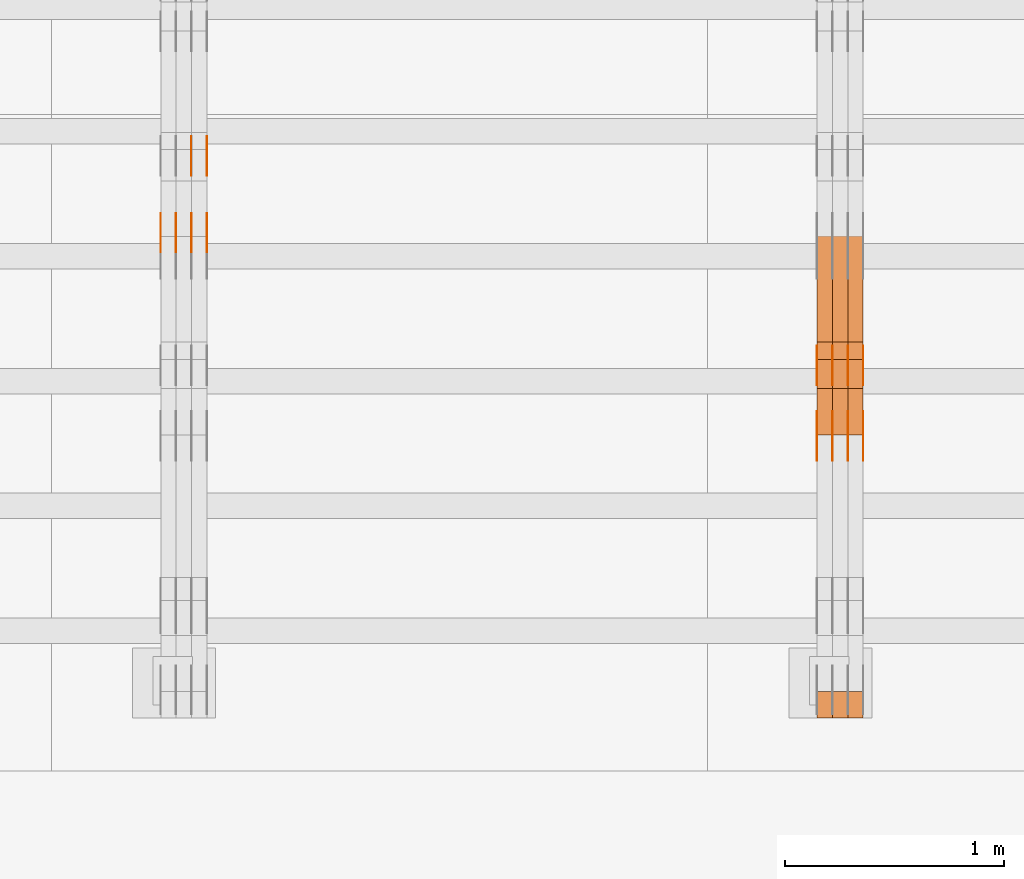
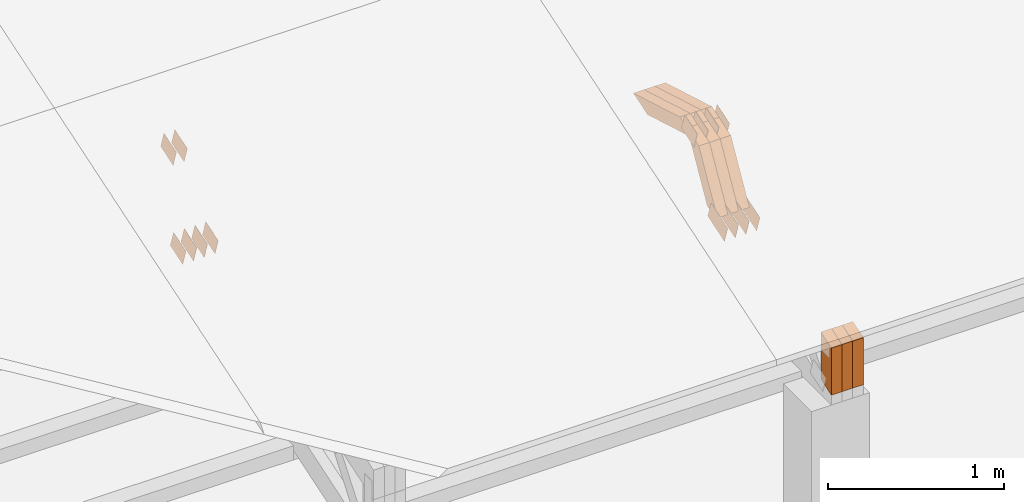
# One storey, part 124 of 385: 29 proxies.
"""IFC2X3 building model written with IfcOpenShell, lengths in millimetres."""

import ifcopenshell
import ifcopenshell.guid

model = None  # the IFC model being written
_history = None  # IfcOwnerHistory: only IFC2X3 demands one
_inside = {}  # id of a spatial element -> (the spatial element, [elements in it])
_under = {}  # id of a project, library or spatial element -> (it, [spatial elements below it])
_declared = {}  # id of a project -> (the project, [libraries it declares])
_typed = {}  # id of a type object -> (the type object, [elements of that type])
_made_of = {}  # id of a material, layer set ... -> (it, [elements and type objects made of it])


def new_model(schema):
    """Start an empty IFC model of exactly this schema.

    Asked for "IFC4X3", IfcOpenShell would pick the latest addendum, in which some entities
    have other attributes; the version numbers below select the first issue.
    IFC2X3 requires an IfcOwnerHistory on every rooted entity: one is made here for all.
    """
    global model, _history
    if schema == "IFC4X3":
        model = ifcopenshell.file(schema_version=(4, 3, 0, 0))
    else:
        model = ifcopenshell.file(schema=schema)
    _inside.clear()
    _under.clear()
    _declared.clear()
    _typed.clear()
    _made_of.clear()
    _history = None
    if model.schema == "IFC2X3":
        org = make("IfcOrganization", Name="unknown")
        user = make(
            "IfcPersonAndOrganization",
            ThePerson=make("IfcPerson", FamilyName="unknown"),
            TheOrganization=org,
        )
        app = make(
            "IfcApplication",
            ApplicationDeveloper=org,
            Version="unknown",
            ApplicationFullName="unknown",
            ApplicationIdentifier="unknown",
        )
        _history = make(
            "IfcOwnerHistory",
            OwningUser=user,
            OwningApplication=app,
            ChangeAction="ADDED",
            CreationDate=0,
        )
    return model


def make(cls, **values):
    """One entity of the class cls with the attributes given. An attribute that is None is left unset."""
    return model.create_entity(
        cls, **{name: value for name, value in values.items() if value is not None}
    )


def entity(cls, *values):
    """Any entity or typed value of the class cls, its attributes in the order of the schema. None: left unset."""
    e = model.create_entity(cls)
    for i, value in enumerate(values):
        if value is not None:
            e[i] = value
    return e


def rooted(cls, **values):
    """An entity with a GlobalId (a new one), such as an element, a storey or a relation."""
    return make(cls, GlobalId=ifcopenshell.guid.new(), OwnerHistory=_history, **values)


def si_unit(unit_type, name, prefix=None):
    """IfcSIUnit, for example si_unit("LENGTHUNIT", "METRE", prefix="MILLI")."""
    return make("IfcSIUnit", UnitType=unit_type, Prefix=prefix, Name=name)


def converted_unit(unit_type, name, factor, base, dimensions=None, offset=None):
    """IfcConversionBasedUnit, such as the inch: factor (a typed value) times the base unit."""
    return make(
        "IfcConversionBasedUnit"
        if offset is None
        else "IfcConversionBasedUnitWithOffset",
        ConversionOffset=offset,
        Dimensions=None
        if dimensions is None
        else entity("IfcDimensionalExponents", *dimensions),
        UnitType=unit_type,
        Name=name,
        ConversionFactor=make(
            "IfcMeasureWithUnit", ValueComponent=factor, UnitComponent=base
        ),
    )


def derived_unit(unit_type, elements):
    """IfcDerivedUnit: a product of units, each with its exponent."""
    return make(
        "IfcDerivedUnit",
        Elements=[
            make("IfcDerivedUnitElement", Unit=unit, Exponent=power)
            for unit, power in elements
        ],
        UnitType=unit_type,
    )


def assignment(units):
    """IfcUnitAssignment: the units of a project."""
    return None if units is None else make("IfcUnitAssignment", Units=units)


def point(xyz):
    """IfcCartesianPoint."""
    return None if xyz is None else make("IfcCartesianPoint", Coordinates=xyz)


def direction(xyz):
    """IfcDirection."""
    return None if xyz is None else make("IfcDirection", DirectionRatios=xyz)


def frame(location, z_axis=None, x_axis=None):
    """IfcAxis2Placement3D, a coordinate frame: its origin and axes. An axis left out is left unset."""
    return make(
        "IfcAxis2Placement3D",
        Location=point(location),
        Axis=direction(z_axis),
        RefDirection=direction(x_axis),
    )


def origin():
    """The frame at (0, 0, 0) with its axes left unset."""
    return frame((0.0, 0.0, 0.0))


def place(relative_to, where):
    """IfcLocalPlacement: puts the frame where relative to a parent placement (None: the world)."""
    return make(
        "IfcLocalPlacement", PlacementRelTo=relative_to, RelativePlacement=where
    )


def context(
    kind, dimensions, precision=None, world=None, true_north=None, identifier=None
):
    """IfcGeometricRepresentationContext, for example the 3D "Model" context."""
    return make(
        "IfcGeometricRepresentationContext",
        ContextIdentifier=identifier,
        ContextType=kind,
        CoordinateSpaceDimension=dimensions,
        Precision=precision,
        WorldCoordinateSystem=world,
        TrueNorth=true_north,
    )


def subcontext(parent, identifier, kind, view, scale=None):
    """IfcGeometricRepresentationSubContext, for example "Body" below "Model"."""
    return make(
        "IfcGeometricRepresentationSubContext",
        ContextIdentifier=identifier,
        ContextType=kind,
        ParentContext=parent,
        TargetScale=scale,
        TargetView=view,
    )


def project(units=None, contexts=None):
    """IfcProject with its units and contexts."""
    return rooted(
        "IfcProject",
        Name="project",
        RepresentationContexts=contexts,
        UnitsInContext=assignment(units),
    )


def spatial(cls, under=None, at=None, **own):
    """A site, building, storey or space (cls), placed at a placement, below another one or the project."""
    s = rooted(cls, ObjectPlacement=at, **own)
    if under is not None:
        _under.setdefault(under.id(), (under, []))[1].append(s)
    return s


def polyline(points):
    """IfcPolyline through the points."""
    return make("IfcPolyline", Points=[point(p) for p in points])


def outline(outer, holes=None, kind="AREA"):
    """IfcArbitraryClosedProfileDef: a profile drawn as a closed curve; with holes, ...WithVoids."""
    if holes is None:
        return make("IfcArbitraryClosedProfileDef", ProfileType=kind, OuterCurve=outer)
    return make(
        "IfcArbitraryProfileDefWithVoids",
        ProfileType=kind,
        OuterCurve=outer,
        InnerCurves=holes,
    )


def extrude(swept, where, along, depth):
    """IfcExtrudedAreaSolid: the profile swept, set in the frame where, extruded along a direction by depth."""
    return make(
        "IfcExtrudedAreaSolid",
        SweptArea=swept,
        Position=where,
        ExtrudedDirection=direction(along),
        Depth=depth,
    )


def shape(context_of_items, identifier, shape_type, items):
    """IfcShapeRepresentation: the items that make up one representation, for example the "Body"."""
    return make(
        "IfcShapeRepresentation",
        ContextOfItems=context_of_items,
        RepresentationIdentifier=identifier,
        RepresentationType=shape_type,
        Items=items,
    )


def source(mapping_origin, context_of_items, identifier, shape_type, items):
    """IfcRepresentationMap: a shape defined once, which mapped items show again and again."""
    return make(
        "IfcRepresentationMap",
        MappingOrigin=mapping_origin,
        MappedRepresentation=shape(context_of_items, identifier, shape_type, items),
    )


def transform(
    local_origin,
    x_axis=None,
    y_axis=None,
    z_axis=None,
    scale=None,
    scale2=None,
    scale3=None,
    uniform=True,
):
    """IfcCartesianTransformationOperator3D, or its non-uniform kind. x_axis, y_axis, z_axis: its Axis1, 2, 3."""
    if uniform:
        return make(
            "IfcCartesianTransformationOperator3D",
            Axis1=direction(x_axis),
            Axis2=direction(y_axis),
            LocalOrigin=point(local_origin),
            Scale=scale,
            Axis3=direction(z_axis),
        )
    return make(
        "IfcCartesianTransformationOperator3DnonUniform",
        Axis1=direction(x_axis),
        Axis2=direction(y_axis),
        LocalOrigin=point(local_origin),
        Scale=scale,
        Axis3=direction(z_axis),
        Scale2=scale2,
        Scale3=scale3,
    )


def mapped(mapping_source, mapping_target):
    """IfcMappedItem: shows the shape of a source again, moved by a transform."""
    return make(
        "IfcMappedItem", MappingSource=mapping_source, MappingTarget=mapping_target
    )


def material(Name=None, Category=None):
    """IfcMaterial."""
    return make("IfcMaterial", Name=Name, Category=Category)


def made_of(thing, what):
    """Note that an element or type object is made of a material, layer set ...; save() writes the relation."""
    if what is not None:
        _made_of.setdefault(what.id(), (what, []))[1].append(thing)
    return thing


def type_object(cls, material=None, **own):
    """A type object (cls), such as IfcWallType, which elements share."""
    return made_of(rooted(cls, **own), material)


def type_shapes(of_type, sources):
    """Give a type object the sources (RepresentationMaps) that its elements show as mapped items."""
    of_type.RepresentationMaps = sources


def element(
    cls,
    number,
    at=None,
    inside=None,
    cuts=None,
    type_object=None,
    material=None,
    context=None,
    identifier="Body",
    shape_type=None,
    held_by="IfcProductDefinitionShape",
    body=None,
    shapes=None,
    **own,
):
    """One element of the class cls, such as IfcWall. Its Tag is "e" and its number.

    at: its placement. inside: the storey or other place that contains it. cuts: it is an
    opening in that element (IfcRelVoidsElement). A single representation is given by context,
    identifier, shape_type and body (its items); several are given by shapes. held_by: the class
    of the entity that holds the representations. save() writes the other relations.
    """
    e = rooted(cls, Tag="e%d" % number, ObjectPlacement=at, **own)
    if body is not None:
        shapes = [shape(context, identifier, shape_type, body)]
    if shapes is not None:
        e.Representation = make(held_by, Representations=shapes)
    if inside is not None:
        _inside.setdefault(inside.id(), (inside, []))[1].append(e)
    if cuts is not None:
        rooted(
            "IfcRelVoidsElement", RelatingBuildingElement=cuts, RelatedOpeningElement=e
        )
    if type_object is not None:
        _typed.setdefault(type_object.id(), (type_object, []))[1].append(e)
    return made_of(e, material)


def aggregate(whole, parts):
    """IfcRelAggregates: a whole, such as a stair, and the parts it consists of."""
    return rooted("IfcRelAggregates", RelatingObject=whole, RelatedObjects=parts)


def save(model, path):
    """Write the relations noted so far, then the file.

    IfcRelAggregates (storeys below a building ...), IfcRelContainedInSpatialStructure (elements
    in a storey), IfcRelDefinesByType, IfcRelAssociatesMaterial and IfcRelDeclares: one each for
    every whole, place, type object, material and project.
    """
    for whole, parts in _under.values():
        aggregate(whole, parts)
    for where, things in _inside.values():
        rooted(
            "IfcRelContainedInSpatialStructure",
            RelatedElements=things,
            RelatingStructure=where,
        )
    for kind, things in _typed.values():
        rooted("IfcRelDefinesByType", RelatedObjects=things, RelatingType=kind)
    for what, things in _made_of.values():
        rooted("IfcRelAssociatesMaterial", RelatedObjects=things, RelatingMaterial=what)
    for by, libraries in _declared.values():
        rooted("IfcRelDeclares", RelatingContext=by, RelatedDefinitions=libraries)
    model.write(path)


model = new_model("IFC2X3")

# Units and contexts
model_context = context("Model", 3, precision=0.01, world=origin(), true_north=direction((6.12303176911189e-17, 1.0)))
body_context = subcontext(model_context, "Body", "Model", "MODEL_VIEW")
ifc_project = project(units=[si_unit("LENGTHUNIT", "METRE", prefix="MILLI"), si_unit("AREAUNIT", "SQUARE_METRE"), si_unit("VOLUMEUNIT", "CUBIC_METRE"), converted_unit("PLANEANGLEUNIT", "DEGREE", entity("IfcRatioMeasure", 0.0174532925199433), si_unit("PLANEANGLEUNIT", "RADIAN"), dimensions=[0, 0, 0, 0, 0, 0, 0]), si_unit("MASSUNIT", "GRAM", prefix="KILO"), derived_unit("MASSDENSITYUNIT", [(si_unit("MASSUNIT", "GRAM", prefix="KILO"), 1), (si_unit("LENGTHUNIT", "METRE"), -3)]), si_unit("TIMEUNIT", "SECOND"), si_unit("FREQUENCYUNIT", "HERTZ"), si_unit("THERMODYNAMICTEMPERATUREUNIT", "DEGREE_CELSIUS"), derived_unit("THERMALTRANSMITTANCEUNIT", [(si_unit("MASSUNIT", "GRAM", prefix="KILO"), 1), (si_unit("THERMODYNAMICTEMPERATUREUNIT", "KELVIN"), -1), (si_unit("TIMEUNIT", "SECOND"), -3)]), derived_unit("VOLUMETRICFLOWRATEUNIT", [(si_unit("LENGTHUNIT", "METRE"), 3), (si_unit("TIMEUNIT", "SECOND"), -1)]), si_unit("ELECTRICCURRENTUNIT", "AMPERE"), si_unit("ELECTRICVOLTAGEUNIT", "VOLT"), si_unit("POWERUNIT", "WATT"), si_unit("FORCEUNIT", "NEWTON", prefix="KILO"), si_unit("ILLUMINANCEUNIT", "LUX"), si_unit("LUMINOUSFLUXUNIT", "LUMEN"), si_unit("LUMINOUSINTENSITYUNIT", "CANDELA"), derived_unit("USERDEFINED", [(si_unit("MASSUNIT", "GRAM", prefix="KILO"), -1), (si_unit("LENGTHUNIT", "METRE"), -2), (si_unit("TIMEUNIT", "SECOND"), 3), (si_unit("LUMINOUSFLUXUNIT", "LUMEN"), 1)]), derived_unit("LINEARVELOCITYUNIT", [(si_unit("LENGTHUNIT", "METRE"), 1), (si_unit("TIMEUNIT", "SECOND"), -1)]), si_unit("PRESSUREUNIT", "PASCAL"), derived_unit("USERDEFINED", [(si_unit("LENGTHUNIT", "METRE"), -2), (si_unit("MASSUNIT", "GRAM", prefix="KILO"), 1), (si_unit("TIMEUNIT", "SECOND"), -2)])], contexts=[model_context])

# Site, building, storey
site_placement = place(None, origin())
site = spatial("IfcSite", under=ifc_project, at=site_placement, CompositionType="ELEMENT")
building_placement = place(site_placement, origin())
building = spatial("IfcBuilding", under=site, at=building_placement, CompositionType="ELEMENT")
storey_placement = place(building_placement, origin())
storey = spatial("IfcBuildingStorey", under=building, at=storey_placement, Name="Default", CompositionType="ELEMENT", Elevation=0.0)

# Proxies
ifc_material_1 = material(Name="IfcSurfaceStyle #339686")
building_element_proxy_type_1 = type_object("IfcBuildingElementProxyType", PredefinedType="NOTDEFINED", material=ifc_material_1)
shared_shape_1 = source(origin(), body_context, "Body", "SweptSolid", [
    extrude(outline(polyline([(-99.9998204243802, -60.000067376167), (99.9998338462265, -60.000067376167), (99.9998204243802, 60.000067376167), (-99.9998338462265, 60.000067376167), (-99.9998204243802, -60.000067376167)])), frame((100.000602015329, 60.0001864986889, 0.0), z_axis=(0.0, 0.0, 1.0), x_axis=(-1.0, 0.0, 0.0)), (0.0, 0.0, 1.0), 1.3),
])
type_shapes(building_element_proxy_type_1, [shared_shape_1])
proxy_1_placement = place(building_placement, frame((27386.3, 4114.85465165112, 513.097031388771), z_axis=(-1.0, 0.0, 0.0), x_axis=(0.0, 0.951056516295124, 0.309016994375039)))
element("IfcBuildingElementProxy", 1, at=proxy_1_placement, inside=storey, type_object=building_element_proxy_type_1, material=ifc_material_1, context=body_context, shape_type="MappedRepresentation", body=[
    mapped(shared_shape_1, transform((0.0, 0.0, 0.0), scale=1.0)),
])
ifc_material_2 = material(Name="IfcSurfaceStyle #339629")
building_element_proxy_type_2 = type_object("IfcBuildingElementProxyType", PredefinedType="NOTDEFINED", material=ifc_material_2)
shared_shape_2 = source(origin(), body_context, "Body", "SweptSolid", [
    extrude(outline(polyline([(-99.9998204243802, -60.000067376167), (99.9998338462265, -60.000067376167), (99.9998204243802, 60.000067376167), (-99.9998338462265, 60.000067376167), (-99.9998204243802, -60.000067376167)])), frame((100.000602015329, 60.0001864986889, 0.0), z_axis=(0.0, 0.0, 1.0), x_axis=(-1.0, 0.0, 0.0)), (0.0, 0.0, 1.0), 1.3),
])
type_shapes(building_element_proxy_type_2, [shared_shape_2])
proxy_2_placement = place(building_placement, frame((27315.0, 4114.85465165112, 513.097031388771), z_axis=(-1.0, 0.0, 0.0), x_axis=(0.0, 0.951056516295124, 0.309016994375039)))
element("IfcBuildingElementProxy", 2, at=proxy_2_placement, inside=storey, type_object=building_element_proxy_type_2, material=ifc_material_2, context=body_context, shape_type="MappedRepresentation", body=[
    mapped(shared_shape_2, transform((0.0, 0.0, 0.0), scale=1.0)),
])
ifc_material_3 = material(Name="IfcSurfaceStyle #339572")
building_element_proxy_type_3 = type_object("IfcBuildingElementProxyType", PredefinedType="NOTDEFINED", material=ifc_material_3)
shared_shape_3 = source(origin(), body_context, "Body", "SweptSolid", [
    extrude(outline(polyline([(-99.9998204243802, -60.000067376167), (99.9998338462265, -60.000067376167), (99.9998204243802, 60.000067376167), (-99.9998338462265, 60.000067376167), (-99.9998204243802, -60.000067376167)])), frame((100.000602015329, 60.0001864986889, 0.0), z_axis=(0.0, 0.0, 1.0), x_axis=(-1.0, 0.0, 0.0)), (0.0, 0.0, 1.0), 1.3),
])
type_shapes(building_element_proxy_type_3, [shared_shape_3])
proxy_3_placement = place(building_placement, frame((27316.3, 4114.85465165112, 513.097031388771), z_axis=(-1.0, 0.0, 0.0), x_axis=(0.0, 0.951056516295124, 0.309016994375039)))
element("IfcBuildingElementProxy", 3, at=proxy_3_placement, inside=storey, type_object=building_element_proxy_type_3, material=ifc_material_3, context=body_context, shape_type="MappedRepresentation", body=[
    mapped(shared_shape_3, transform((0.0, 0.0, 0.0), scale=1.0)),
])
ifc_material_4 = material(Name="IfcSurfaceStyle #339515")
building_element_proxy_type_4 = type_object("IfcBuildingElementProxyType", PredefinedType="NOTDEFINED", material=ifc_material_4)
shared_shape_4 = source(origin(), body_context, "Body", "SweptSolid", [
    extrude(outline(polyline([(-99.9998204243802, -60.000067376167), (99.9998338462265, -60.000067376167), (99.9998204243802, 60.000067376167), (-99.9998338462265, 60.000067376167), (-99.9998204243802, -60.000067376167)])), frame((100.000602015329, 60.0001864986889, 0.0), z_axis=(0.0, 0.0, 1.0), x_axis=(-1.0, 0.0, 0.0)), (0.0, 0.0, 1.0), 1.29999999999998),
])
type_shapes(building_element_proxy_type_4, [shared_shape_4])
proxy_4_placement = place(building_placement, frame((27245.0, 4114.85465165112, 513.097031388771), z_axis=(-1.0, 0.0, 0.0), x_axis=(0.0, 0.951056516295124, 0.309016994375039)))
element("IfcBuildingElementProxy", 4, at=proxy_4_placement, inside=storey, type_object=building_element_proxy_type_4, material=ifc_material_4, context=body_context, shape_type="MappedRepresentation", body=[
    mapped(shared_shape_4, transform((0.0, 0.0, 0.0), scale=1.0)),
])
ifc_material_5 = material(Name="IfcSurfaceStyle #339458")
building_element_proxy_type_5 = type_object("IfcBuildingElementProxyType", PredefinedType="NOTDEFINED", material=ifc_material_5)
shared_shape_5 = source(origin(), body_context, "Body", "SweptSolid", [
    extrude(outline(polyline([(-99.9998204243802, -60.000067376167), (99.9998338462265, -60.000067376167), (99.9998204243802, 60.000067376167), (-99.9998338462265, 60.000067376167), (-99.9998204243802, -60.000067376167)])), frame((100.000602015329, 60.0001864986889, 0.0), z_axis=(0.0, 0.0, 1.0), x_axis=(-1.0, 0.0, 0.0)), (0.0, 0.0, 1.0), 1.29999999999998),
])
type_shapes(building_element_proxy_type_5, [shared_shape_5])
proxy_5_placement = place(building_placement, frame((27246.3, 4114.85465165112, 513.097031388771), z_axis=(-1.0, 0.0, 0.0), x_axis=(0.0, 0.951056516295124, 0.309016994375039)))
element("IfcBuildingElementProxy", 5, at=proxy_5_placement, inside=storey, type_object=building_element_proxy_type_5, material=ifc_material_5, context=body_context, shape_type="MappedRepresentation", body=[
    mapped(shared_shape_5, transform((0.0, 0.0, 0.0), scale=1.0)),
])
ifc_material_6 = material(Name="IfcSurfaceStyle #339401")
building_element_proxy_type_6 = type_object("IfcBuildingElementProxyType", PredefinedType="NOTDEFINED", material=ifc_material_6)
shared_shape_6 = source(origin(), body_context, "Body", "SweptSolid", [
    extrude(outline(polyline([(-99.9998204243802, -60.000067376167), (99.9998338462265, -60.000067376167), (99.9998204243802, 60.000067376167), (-99.9998338462265, 60.000067376167), (-99.9998204243802, -60.000067376167)])), frame((100.000602015329, 60.0001864986889, 0.0), z_axis=(0.0, 0.0, 1.0), x_axis=(-1.0, 0.0, 0.0)), (0.0, 0.0, 1.0), 1.29999999999999),
])
type_shapes(building_element_proxy_type_6, [shared_shape_6])
proxy_6_placement = place(building_placement, frame((27175.0, 4114.85465165112, 513.097031388771), z_axis=(-1.0, 0.0, 0.0), x_axis=(0.0, 0.951056516295124, 0.309016994375039)))
element("IfcBuildingElementProxy", 6, at=proxy_6_placement, inside=storey, type_object=building_element_proxy_type_6, material=ifc_material_6, context=body_context, shape_type="MappedRepresentation", body=[
    mapped(shared_shape_6, transform((0.0, 0.0, 0.0), scale=1.0)),
])
ifc_material_7 = material(Name="IfcSurfaceStyle #332504")
building_element_proxy_type_7 = type_object("IfcBuildingElementProxyType", PredefinedType="NOTDEFINED", material=ifc_material_7)
shared_shape_7 = source(origin(), body_context, "Body", "SweptSolid", [
    extrude(outline(polyline([(-74.999865998172, -60.0000306612919), (74.999869989555, -60.0000306612919), (74.999865998172, 60.0000306612919), (-74.999869989555, 60.0000306612919), (-74.999865998172, -60.0000306612919)])), frame((75.0006726017528, 60.0001996460842, 0.0), z_axis=(0.0, 0.0, 1.0), x_axis=(-1.0, 0.0, 0.0)), (0.0, 0.0, 1.0), 1.3),
])
type_shapes(building_element_proxy_type_7, [shared_shape_7])
proxy_7_placement = place(building_placement, frame((27386.3, 4460.38978242656, 957.314497110567), z_axis=(-1.0, 0.0, 0.0), x_axis=(0.0, 0.951056516295154, 0.309016994374948)))
element("IfcBuildingElementProxy", 7, at=proxy_7_placement, inside=storey, type_object=building_element_proxy_type_7, material=ifc_material_7, context=body_context, shape_type="MappedRepresentation", body=[
    mapped(shared_shape_7, transform((0.0, 0.0, 0.0), scale=1.0)),
])
ifc_material_8 = material(Name="IfcSurfaceStyle #332447")
building_element_proxy_type_8 = type_object("IfcBuildingElementProxyType", PredefinedType="NOTDEFINED", material=ifc_material_8)
shared_shape_8 = source(origin(), body_context, "Body", "SweptSolid", [
    extrude(outline(polyline([(-74.999865998172, -60.0000306612919), (74.999869989555, -60.0000306612919), (74.999865998172, 60.0000306612919), (-74.999869989555, 60.0000306612919), (-74.999865998172, -60.0000306612919)])), frame((75.0006726017528, 60.0001996460842, 0.0), z_axis=(0.0, 0.0, 1.0), x_axis=(-1.0, 0.0, 0.0)), (0.0, 0.0, 1.0), 1.3),
])
type_shapes(building_element_proxy_type_8, [shared_shape_8])
proxy_8_placement = place(building_placement, frame((27315.0, 4460.38978242656, 957.314497110567), z_axis=(-1.0, 0.0, 0.0), x_axis=(0.0, 0.951056516295154, 0.309016994374948)))
element("IfcBuildingElementProxy", 8, at=proxy_8_placement, inside=storey, type_object=building_element_proxy_type_8, material=ifc_material_8, context=body_context, shape_type="MappedRepresentation", body=[
    mapped(shared_shape_8, transform((0.0, 0.0, 0.0), scale=1.0)),
])
ifc_material_9 = material(Name="IfcSurfaceStyle #332390")
building_element_proxy_type_9 = type_object("IfcBuildingElementProxyType", PredefinedType="NOTDEFINED", material=ifc_material_9)
shared_shape_9 = source(origin(), body_context, "Body", "SweptSolid", [
    extrude(outline(polyline([(-74.999865998172, -60.0000306612919), (74.999869989555, -60.0000306612919), (74.999865998172, 60.0000306612919), (-74.999869989555, 60.0000306612919), (-74.999865998172, -60.0000306612919)])), frame((75.0006726017528, 60.0001996460842, 0.0), z_axis=(0.0, 0.0, 1.0), x_axis=(-1.0, 0.0, 0.0)), (0.0, 0.0, 1.0), 1.3),
])
type_shapes(building_element_proxy_type_9, [shared_shape_9])
proxy_9_placement = place(building_placement, frame((27316.3, 4460.38978242656, 957.314497110567), z_axis=(-1.0, 0.0, 0.0), x_axis=(0.0, 0.951056516295154, 0.309016994374948)))
element("IfcBuildingElementProxy", 9, at=proxy_9_placement, inside=storey, type_object=building_element_proxy_type_9, material=ifc_material_9, context=body_context, shape_type="MappedRepresentation", body=[
    mapped(shared_shape_9, transform((0.0, 0.0, 0.0), scale=1.0)),
])
ifc_material_10 = material(Name="IfcSurfaceStyle #332333")
building_element_proxy_type_10 = type_object("IfcBuildingElementProxyType", PredefinedType="NOTDEFINED", material=ifc_material_10)
shared_shape_10 = source(origin(), body_context, "Body", "SweptSolid", [
    extrude(outline(polyline([(-74.999865998172, -60.0000306612919), (74.999869989555, -60.0000306612919), (74.999865998172, 60.0000306612919), (-74.999869989555, 60.0000306612919), (-74.999865998172, -60.0000306612919)])), frame((75.0006726017528, 60.0001996460842, 0.0), z_axis=(0.0, 0.0, 1.0), x_axis=(-1.0, 0.0, 0.0)), (0.0, 0.0, 1.0), 1.29999999999999),
])
type_shapes(building_element_proxy_type_10, [shared_shape_10])
proxy_10_placement = place(building_placement, frame((27245.0, 4460.38978242656, 957.314497110567), z_axis=(-1.0, 0.0, 0.0), x_axis=(0.0, 0.951056516295154, 0.309016994374948)))
element("IfcBuildingElementProxy", 10, at=proxy_10_placement, inside=storey, type_object=building_element_proxy_type_10, material=ifc_material_10, context=body_context, shape_type="MappedRepresentation", body=[
    mapped(shared_shape_10, transform((0.0, 0.0, 0.0), scale=1.0)),
])
ifc_material_11 = material(Name="IfcSurfaceStyle #332276")
building_element_proxy_type_11 = type_object("IfcBuildingElementProxyType", PredefinedType="NOTDEFINED", material=ifc_material_11)
shared_shape_11 = source(origin(), body_context, "Body", "SweptSolid", [
    extrude(outline(polyline([(-74.999865998172, -60.0000306612919), (74.999869989555, -60.0000306612919), (74.999865998172, 60.0000306612919), (-74.999869989555, 60.0000306612919), (-74.999865998172, -60.0000306612919)])), frame((75.0006726017528, 60.0001996460842, 0.0), z_axis=(0.0, 0.0, 1.0), x_axis=(-1.0, 0.0, 0.0)), (0.0, 0.0, 1.0), 1.29999999999999),
])
type_shapes(building_element_proxy_type_11, [shared_shape_11])
proxy_11_placement = place(building_placement, frame((27246.3, 4460.38978242656, 957.314497110567), z_axis=(-1.0, 0.0, 0.0), x_axis=(0.0, 0.951056516295154, 0.309016994374948)))
element("IfcBuildingElementProxy", 11, at=proxy_11_placement, inside=storey, type_object=building_element_proxy_type_11, material=ifc_material_11, context=body_context, shape_type="MappedRepresentation", body=[
    mapped(shared_shape_11, transform((0.0, 0.0, 0.0), scale=1.0)),
])
ifc_material_12 = material(Name="IfcSurfaceStyle #332219")
building_element_proxy_type_12 = type_object("IfcBuildingElementProxyType", PredefinedType="NOTDEFINED", material=ifc_material_12)
shared_shape_12 = source(origin(), body_context, "Body", "SweptSolid", [
    extrude(outline(polyline([(-74.999865998172, -60.0000306612919), (74.999869989555, -60.0000306612919), (74.999865998172, 60.0000306612919), (-74.999869989555, 60.0000306612919), (-74.999865998172, -60.0000306612919)])), frame((75.0006726017528, 60.0001996460842, 0.0), z_axis=(0.0, 0.0, 1.0), x_axis=(-1.0, 0.0, 0.0)), (0.0, 0.0, 1.0), 1.29999999999999),
])
type_shapes(building_element_proxy_type_12, [shared_shape_12])
proxy_12_placement = place(building_placement, frame((27175.0, 4460.38978242656, 957.314497110567), z_axis=(-1.0, 0.0, 0.0), x_axis=(0.0, 0.951056516295154, 0.309016994374948)))
element("IfcBuildingElementProxy", 12, at=proxy_12_placement, inside=storey, type_object=building_element_proxy_type_12, material=ifc_material_12, context=body_context, shape_type="MappedRepresentation", body=[
    mapped(shared_shape_12, transform((0.0, 0.0, 0.0), scale=1.0)),
])
ifc_material_13 = material(Name="IfcSurfaceStyle #319976")
building_element_proxy_type_13 = type_object("IfcBuildingElementProxyType", Name="T1-W12 319974", PredefinedType="NOTDEFINED", material=ifc_material_13)
shared_shape_13 = source(origin(), body_context, "Body", "SweptSolid", [
    extrude(outline(polyline([(-249.405625983165, -47.5001691155616), (243.345753908996, -47.5001691155616), (232.115534842595, 2.39993474701938e-05), (162.527010966644, 47.5001571158879), (-388.58267373507, 47.5001571158879), (-249.405625983165, -47.5001691155616)])), frame((243.345867653852, 47.5001571158879, 0.0), z_axis=(0.0, 0.0, 1.0), x_axis=(-1.0, 0.0, 0.0)), (0.0, 0.0, 1.0), 70.0),
])
type_shapes(building_element_proxy_type_13, [shared_shape_13])
proxy_13_placement = place(building_placement, frame((27385.0, 4581.32698473632, 976.172276753357), z_axis=(-1.0, 0.0, 0.0), x_axis=(0.0, 0.959722067881787, -0.280951156645966)))
element("IfcBuildingElementProxy", 13, at=proxy_13_placement, inside=storey, type_object=building_element_proxy_type_13, material=ifc_material_13, Name="T1-W12", context=body_context, shape_type="MappedRepresentation", body=[
    mapped(shared_shape_13, transform((0.0, 0.0, 0.0), scale=1.0)),
])
ifc_material_14 = material(Name="IfcSurfaceStyle #319910")
building_element_proxy_type_14 = type_object("IfcBuildingElementProxyType", Name="T1-W12 319908", PredefinedType="NOTDEFINED", material=ifc_material_14)
shared_shape_14 = source(origin(), body_context, "Body", "SweptSolid", [
    extrude(outline(polyline([(-249.405625983165, -47.5001691155616), (243.345753908996, -47.5001691155616), (232.115534842595, 2.39993474701938e-05), (162.527010966644, 47.5001571158879), (-388.58267373507, 47.5001571158879), (-249.405625983165, -47.5001691155616)])), frame((243.345867653852, 47.5001571158879, 0.0), z_axis=(0.0, 0.0, 1.0), x_axis=(-1.0, 0.0, 0.0)), (0.0, 0.0, 1.0), 70.0),
])
type_shapes(building_element_proxy_type_14, [shared_shape_14])
proxy_14_placement = place(building_placement, frame((27315.0, 4581.32698473632, 976.172276753357), z_axis=(-1.0, 0.0, 0.0), x_axis=(0.0, 0.959722067881787, -0.280951156645966)))
element("IfcBuildingElementProxy", 14, at=proxy_14_placement, inside=storey, type_object=building_element_proxy_type_14, material=ifc_material_14, Name="T1-W12", context=body_context, shape_type="MappedRepresentation", body=[
    mapped(shared_shape_14, transform((0.0, 0.0, 0.0), scale=1.0)),
])
ifc_material_15 = material(Name="IfcSurfaceStyle #319844")
building_element_proxy_type_15 = type_object("IfcBuildingElementProxyType", Name="T1-W12 319842", PredefinedType="NOTDEFINED", material=ifc_material_15)
shared_shape_15 = source(origin(), body_context, "Body", "SweptSolid", [
    extrude(outline(polyline([(-249.405625983165, -47.5001691155616), (243.345753908996, -47.5001691155616), (232.115534842595, 2.39993474701938e-05), (162.527010966644, 47.5001571158879), (-388.58267373507, 47.5001571158879), (-249.405625983165, -47.5001691155616)])), frame((243.345867653852, 47.5001571158879, 0.0), z_axis=(0.0, 0.0, 1.0), x_axis=(-1.0, 0.0, 0.0)), (0.0, 0.0, 1.0), 70.0),
])
type_shapes(building_element_proxy_type_15, [shared_shape_15])
proxy_15_placement = place(building_placement, frame((27245.0, 4581.32698473632, 976.172276753357), z_axis=(-1.0, 0.0, 0.0), x_axis=(0.0, 0.959722067881787, -0.280951156645966)))
element("IfcBuildingElementProxy", 15, at=proxy_15_placement, inside=storey, type_object=building_element_proxy_type_15, material=ifc_material_15, Name="T1-W12", context=body_context, shape_type="MappedRepresentation", body=[
    mapped(shared_shape_15, transform((0.0, 0.0, 0.0), scale=1.0)),
])
ifc_material_16 = material(Name="IfcSurfaceStyle #319580")
building_element_proxy_type_16 = type_object("IfcBuildingElementProxyType", Name="T1-W27 319578", PredefinedType="NOTDEFINED", material=ifc_material_16)
shared_shape_16 = source(origin(), body_context, "Body", "SweptSolid", [
    extrude(outline(polyline([(-321.979763159708, -47.49993999164), (138.960018341432, -47.49993999164), (191.013775341887, -0.000473170132329126), (209.87827169492, 47.5001765767061), (-217.872302218531, 47.5001765767062), (-321.979763159708, -47.49993999164)])), frame((209.87827169492, 47.5001765767061, 0.0), z_axis=(0.0, 0.0, 1.0), x_axis=(-1.0, 0.0, 0.0)), (0.0, 0.0, 1.0), 70.0),
])
type_shapes(building_element_proxy_type_16, [shared_shape_16])
proxy_16_placement = place(building_placement, frame((27385.0, 4233.3125, 512.021728515625), z_axis=(-1.0, 0.0, 0.0), x_axis=(0.0, 0.494231057369727, 0.869330582650352)))
element("IfcBuildingElementProxy", 16, at=proxy_16_placement, inside=storey, type_object=building_element_proxy_type_16, material=ifc_material_16, Name="T1-W27", context=body_context, shape_type="MappedRepresentation", body=[
    mapped(shared_shape_16, transform((0.0, 0.0, 0.0), scale=1.0)),
])
ifc_material_17 = material(Name="IfcSurfaceStyle #319514")
building_element_proxy_type_17 = type_object("IfcBuildingElementProxyType", Name="T1-W27 319512", PredefinedType="NOTDEFINED", material=ifc_material_17)
shared_shape_17 = source(origin(), body_context, "Body", "SweptSolid", [
    extrude(outline(polyline([(-321.979763159708, -47.49993999164), (138.960018341432, -47.49993999164), (191.013775341887, -0.000473170132329126), (209.87827169492, 47.5001765767061), (-217.872302218531, 47.5001765767062), (-321.979763159708, -47.49993999164)])), frame((209.87827169492, 47.5001765767061, 0.0), z_axis=(0.0, 0.0, 1.0), x_axis=(-1.0, 0.0, 0.0)), (0.0, 0.0, 1.0), 70.0),
])
type_shapes(building_element_proxy_type_17, [shared_shape_17])
proxy_17_placement = place(building_placement, frame((27315.0, 4233.3125, 512.021728515625), z_axis=(-1.0, 0.0, 0.0), x_axis=(0.0, 0.494231057369727, 0.869330582650352)))
element("IfcBuildingElementProxy", 17, at=proxy_17_placement, inside=storey, type_object=building_element_proxy_type_17, material=ifc_material_17, Name="T1-W27", context=body_context, shape_type="MappedRepresentation", body=[
    mapped(shared_shape_17, transform((0.0, 0.0, 0.0), scale=1.0)),
])
ifc_material_18 = material(Name="IfcSurfaceStyle #319448")
building_element_proxy_type_18 = type_object("IfcBuildingElementProxyType", Name="T1-W27 319446", PredefinedType="NOTDEFINED", material=ifc_material_18)
shared_shape_18 = source(origin(), body_context, "Body", "SweptSolid", [
    extrude(outline(polyline([(-321.979763159708, -47.49993999164), (138.960018341432, -47.49993999164), (191.013775341887, -0.000473170132329126), (209.87827169492, 47.5001765767061), (-217.872302218531, 47.5001765767062), (-321.979763159708, -47.49993999164)])), frame((209.87827169492, 47.5001765767061, 0.0), z_axis=(0.0, 0.0, 1.0), x_axis=(-1.0, 0.0, 0.0)), (0.0, 0.0, 1.0), 70.0),
])
type_shapes(building_element_proxy_type_18, [shared_shape_18])
proxy_18_placement = place(building_placement, frame((27245.0, 4233.3125, 512.021728515625), z_axis=(-1.0, 0.0, 0.0), x_axis=(0.0, 0.494231057369727, 0.869330582650352)))
element("IfcBuildingElementProxy", 18, at=proxy_18_placement, inside=storey, type_object=building_element_proxy_type_18, material=ifc_material_18, Name="T1-W27", context=body_context, shape_type="MappedRepresentation", body=[
    mapped(shared_shape_18, transform((0.0, 0.0, 0.0), scale=1.0)),
])
ifc_material_19 = material(Name="IfcSurfaceStyle #318590")
building_element_proxy_type_19 = type_object("IfcBuildingElementProxyType", Name="T1-E3 318588", PredefinedType="NOTDEFINED", material=ifc_material_19)
shared_shape_19 = source(origin(), body_context, "Body", "SweptSolid", [
    extrude(outline(polyline([(-182.839673995971, -60.0), (143.849313735962, -60.0), (182.839677810669, 60.0), (-143.84931755066, 60.0), (-182.839673995971, -60.0)])), frame((182.839677810669, 60.0, 0.0), z_axis=(0.0, 0.0, 1.0), x_axis=(-1.0, 0.0, 0.0)), (0.0, 0.0, 1.0), 70.0),
])
type_shapes(building_element_proxy_type_19, [shared_shape_19])
proxy_19_placement = place(building_placement, frame((27385.0, 2940.0, 68.27587890625), z_axis=(-1.0, 0.0, 0.0), x_axis=(0.0, 0.0, 1.0)))
element("IfcBuildingElementProxy", 19, at=proxy_19_placement, inside=storey, type_object=building_element_proxy_type_19, material=ifc_material_19, Name="T1-E3", context=body_context, shape_type="MappedRepresentation", body=[
    mapped(shared_shape_19, transform((0.0, 0.0, 0.0), scale=1.0)),
])
ifc_material_20 = material(Name="IfcSurfaceStyle #318533")
building_element_proxy_type_20 = type_object("IfcBuildingElementProxyType", Name="T1-E3 318531", PredefinedType="NOTDEFINED", material=ifc_material_20)
shared_shape_20 = source(origin(), body_context, "Body", "SweptSolid", [
    extrude(outline(polyline([(-182.839673995971, -60.0), (143.849313735962, -60.0), (182.839677810669, 60.0), (-143.84931755066, 60.0), (-182.839673995971, -60.0)])), frame((182.839677810669, 60.0, 0.0), z_axis=(0.0, 0.0, 1.0), x_axis=(-1.0, 0.0, 0.0)), (0.0, 0.0, 1.0), 70.0),
])
type_shapes(building_element_proxy_type_20, [shared_shape_20])
proxy_20_placement = place(building_placement, frame((27315.0, 2940.0, 68.27587890625), z_axis=(-1.0, 0.0, 0.0), x_axis=(0.0, 0.0, 1.0)))
element("IfcBuildingElementProxy", 20, at=proxy_20_placement, inside=storey, type_object=building_element_proxy_type_20, material=ifc_material_20, Name="T1-E3", context=body_context, shape_type="MappedRepresentation", body=[
    mapped(shared_shape_20, transform((0.0, 0.0, 0.0), scale=1.0)),
])
ifc_material_21 = material(Name="IfcSurfaceStyle #318476")
building_element_proxy_type_21 = type_object("IfcBuildingElementProxyType", Name="T1-E3 318474", PredefinedType="NOTDEFINED", material=ifc_material_21)
shared_shape_21 = source(origin(), body_context, "Body", "SweptSolid", [
    extrude(outline(polyline([(-182.839673995971, -60.0), (143.849313735962, -60.0), (182.839677810669, 60.0), (-143.84931755066, 60.0), (-182.839673995971, -60.0)])), frame((182.839677810669, 60.0, 0.0), z_axis=(0.0, 0.0, 1.0), x_axis=(-1.0, 0.0, 0.0)), (0.0, 0.0, 1.0), 70.0),
])
type_shapes(building_element_proxy_type_21, [shared_shape_21])
proxy_21_placement = place(building_placement, frame((27245.0, 2940.0, 68.27587890625), z_axis=(-1.0, 0.0, 0.0), x_axis=(0.0, 0.0, 1.0)))
element("IfcBuildingElementProxy", 21, at=proxy_21_placement, inside=storey, type_object=building_element_proxy_type_21, material=ifc_material_21, Name="T1-E3", context=body_context, shape_type="MappedRepresentation", body=[
    mapped(shared_shape_21, transform((0.0, 0.0, 0.0), scale=1.0)),
])
ifc_material_22 = material(Name="IfcSurfaceStyle #304912")
building_element_proxy_type_22 = type_object("IfcBuildingElementProxyType", PredefinedType="NOTDEFINED", material=ifc_material_22)
shared_shape_22 = source(origin(), body_context, "Body", "SweptSolid", [
    extrude(outline(polyline([(-74.9998707133927, -60.0000596852269), (74.9998841352353, -60.0000596852269), (74.999861282944, 60.0000596852269), (-74.9998747047866, 60.0000596852269), (-74.9998707133927, -60.0000596852269)])), frame((74.9998841352353, 60.0000596852269, 0.0), z_axis=(0.0, 0.0, 1.0), x_axis=(-1.0, 0.0, 0.0)), (0.0, 0.0, 1.0), 1.3),
])
type_shapes(building_element_proxy_type_22, [shared_shape_22])
proxy_22_placement = place(building_placement, frame((24386.3, 5067.4882362875, 826.131473120182), z_axis=(-1.0, 0.0, 0.0), x_axis=(0.0, 0.951056516295124, 0.309016994375039)))
element("IfcBuildingElementProxy", 22, at=proxy_22_placement, inside=storey, type_object=building_element_proxy_type_22, material=ifc_material_22, context=body_context, shape_type="MappedRepresentation", body=[
    mapped(shared_shape_22, transform((0.0, 0.0, 0.0), scale=1.0)),
])
ifc_material_23 = material(Name="IfcSurfaceStyle #304855")
building_element_proxy_type_23 = type_object("IfcBuildingElementProxyType", PredefinedType="NOTDEFINED", material=ifc_material_23)
shared_shape_23 = source(origin(), body_context, "Body", "SweptSolid", [
    extrude(outline(polyline([(-74.9998707133927, -60.0000596852269), (74.9998841352353, -60.0000596852269), (74.999861282944, 60.0000596852269), (-74.9998747047866, 60.0000596852269), (-74.9998707133927, -60.0000596852269)])), frame((74.9998841352353, 60.0000596852269, 0.0), z_axis=(0.0, 0.0, 1.0), x_axis=(-1.0, 0.0, 0.0)), (0.0, 0.0, 1.0), 1.3),
])
type_shapes(building_element_proxy_type_23, [shared_shape_23])
proxy_23_placement = place(building_placement, frame((24315.0, 5067.4882362875, 826.131473120182), z_axis=(-1.0, 0.0, 0.0), x_axis=(0.0, 0.951056516295124, 0.309016994375039)))
element("IfcBuildingElementProxy", 23, at=proxy_23_placement, inside=storey, type_object=building_element_proxy_type_23, material=ifc_material_23, context=body_context, shape_type="MappedRepresentation", body=[
    mapped(shared_shape_23, transform((0.0, 0.0, 0.0), scale=1.0)),
])
ifc_material_24 = material(Name="IfcSurfaceStyle #304798")
building_element_proxy_type_24 = type_object("IfcBuildingElementProxyType", PredefinedType="NOTDEFINED", material=ifc_material_24)
shared_shape_24 = source(origin(), body_context, "Body", "SweptSolid", [
    extrude(outline(polyline([(-74.9998707133927, -60.0000596852269), (74.9998841352353, -60.0000596852269), (74.999861282944, 60.0000596852269), (-74.9998747047866, 60.0000596852269), (-74.9998707133927, -60.0000596852269)])), frame((74.9998841352353, 60.0000596852269, 0.0), z_axis=(0.0, 0.0, 1.0), x_axis=(-1.0, 0.0, 0.0)), (0.0, 0.0, 1.0), 1.3),
])
type_shapes(building_element_proxy_type_24, [shared_shape_24])
proxy_24_placement = place(building_placement, frame((24316.3, 5067.4882362875, 826.131473120182), z_axis=(-1.0, 0.0, 0.0), x_axis=(0.0, 0.951056516295124, 0.309016994375039)))
element("IfcBuildingElementProxy", 24, at=proxy_24_placement, inside=storey, type_object=building_element_proxy_type_24, material=ifc_material_24, context=body_context, shape_type="MappedRepresentation", body=[
    mapped(shared_shape_24, transform((0.0, 0.0, 0.0), scale=1.0)),
])
ifc_material_25 = material(Name="IfcSurfaceStyle #304741")
building_element_proxy_type_25 = type_object("IfcBuildingElementProxyType", PredefinedType="NOTDEFINED", material=ifc_material_25)
shared_shape_25 = source(origin(), body_context, "Body", "SweptSolid", [
    extrude(outline(polyline([(-74.9998707133927, -60.0000596852269), (74.9998841352353, -60.0000596852269), (74.999861282944, 60.0000596852269), (-74.9998747047866, 60.0000596852269), (-74.9998707133927, -60.0000596852269)])), frame((74.9998841352353, 60.0000596852269, 0.0), z_axis=(0.0, 0.0, 1.0), x_axis=(-1.0, 0.0, 0.0)), (0.0, 0.0, 1.0), 1.29999999999999),
])
type_shapes(building_element_proxy_type_25, [shared_shape_25])
proxy_25_placement = place(building_placement, frame((24245.0, 5067.4882362875, 826.131473120182), z_axis=(-1.0, 0.0, 0.0), x_axis=(0.0, 0.951056516295124, 0.309016994375039)))
element("IfcBuildingElementProxy", 25, at=proxy_25_placement, inside=storey, type_object=building_element_proxy_type_25, material=ifc_material_25, context=body_context, shape_type="MappedRepresentation", body=[
    mapped(shared_shape_25, transform((0.0, 0.0, 0.0), scale=1.0)),
])
ifc_material_26 = material(Name="IfcSurfaceStyle #304684")
building_element_proxy_type_26 = type_object("IfcBuildingElementProxyType", PredefinedType="NOTDEFINED", material=ifc_material_26)
shared_shape_26 = source(origin(), body_context, "Body", "SweptSolid", [
    extrude(outline(polyline([(-74.9998707133927, -60.0000596852269), (74.9998841352353, -60.0000596852269), (74.999861282944, 60.0000596852269), (-74.9998747047866, 60.0000596852269), (-74.9998707133927, -60.0000596852269)])), frame((74.9998841352353, 60.0000596852269, 0.0), z_axis=(0.0, 0.0, 1.0), x_axis=(-1.0, 0.0, 0.0)), (0.0, 0.0, 1.0), 1.29999999999999),
])
type_shapes(building_element_proxy_type_26, [shared_shape_26])
proxy_26_placement = place(building_placement, frame((24246.3, 5067.4882362875, 826.131473120182), z_axis=(-1.0, 0.0, 0.0), x_axis=(0.0, 0.951056516295124, 0.309016994375039)))
element("IfcBuildingElementProxy", 26, at=proxy_26_placement, inside=storey, type_object=building_element_proxy_type_26, material=ifc_material_26, context=body_context, shape_type="MappedRepresentation", body=[
    mapped(shared_shape_26, transform((0.0, 0.0, 0.0), scale=1.0)),
])
ifc_material_27 = material(Name="IfcSurfaceStyle #304627")
building_element_proxy_type_27 = type_object("IfcBuildingElementProxyType", PredefinedType="NOTDEFINED", material=ifc_material_27)
shared_shape_27 = source(origin(), body_context, "Body", "SweptSolid", [
    extrude(outline(polyline([(-74.9998707133927, -60.0000596852269), (74.9998841352353, -60.0000596852269), (74.999861282944, 60.0000596852269), (-74.9998747047866, 60.0000596852269), (-74.9998707133927, -60.0000596852269)])), frame((74.9998841352353, 60.0000596852269, 0.0), z_axis=(0.0, 0.0, 1.0), x_axis=(-1.0, 0.0, 0.0)), (0.0, 0.0, 1.0), 1.29999999999999),
])
type_shapes(building_element_proxy_type_27, [shared_shape_27])
proxy_27_placement = place(building_placement, frame((24175.0, 5067.4882362875, 826.131473120182), z_axis=(-1.0, 0.0, 0.0), x_axis=(0.0, 0.951056516295124, 0.309016994375039)))
element("IfcBuildingElementProxy", 27, at=proxy_27_placement, inside=storey, type_object=building_element_proxy_type_27, material=ifc_material_27, context=body_context, shape_type="MappedRepresentation", body=[
    mapped(shared_shape_27, transform((0.0, 0.0, 0.0), scale=1.0)),
])
ifc_material_28 = material(Name="IfcSurfaceStyle #299098")
building_element_proxy_type_28 = type_object("IfcBuildingElementProxyType", PredefinedType="NOTDEFINED", material=ifc_material_28)
shared_shape_28 = source(origin(), body_context, "Body", "SweptSolid", [
    extrude(outline(polyline([(-74.9998565677224, -60.0000596852342), (74.9998794200083, -60.0000596852342), (74.9998565677242, 60.0000596852342), (-74.9998794200101, 60.0000596852342), (-74.9998565677224, -60.0000596852342)])), frame((74.9998794200083, 60.0000596852342, 0.0), z_axis=(0.0, 0.0, 1.0), x_axis=(-1.0, 0.0, 0.0)), (0.0, 0.0, 1.0), 1.3),
])
type_shapes(building_element_proxy_type_28, [shared_shape_28])
proxy_28_placement = place(building_placement, frame((24386.3, 5418.6991737875, 1250.81341892098), z_axis=(-1.0, 0.0, 0.0), x_axis=(0.0, 0.951056516295154, 0.309016994374948)))
element("IfcBuildingElementProxy", 28, at=proxy_28_placement, inside=storey, type_object=building_element_proxy_type_28, material=ifc_material_28, context=body_context, shape_type="MappedRepresentation", body=[
    mapped(shared_shape_28, transform((0.0, 0.0, 0.0), scale=1.0)),
])
ifc_material_29 = material(Name="IfcSurfaceStyle #299041")
building_element_proxy_type_29 = type_object("IfcBuildingElementProxyType", PredefinedType="NOTDEFINED", material=ifc_material_29)
shared_shape_29 = source(origin(), body_context, "Body", "SweptSolid", [
    extrude(outline(polyline([(-74.9998565677224, -60.0000596852342), (74.9998794200083, -60.0000596852342), (74.9998565677242, 60.0000596852342), (-74.9998794200101, 60.0000596852342), (-74.9998565677224, -60.0000596852342)])), frame((74.9998794200083, 60.0000596852342, 0.0), z_axis=(0.0, 0.0, 1.0), x_axis=(-1.0, 0.0, 0.0)), (0.0, 0.0, 1.0), 1.3),
])
type_shapes(building_element_proxy_type_29, [shared_shape_29])
proxy_29_placement = place(building_placement, frame((24315.0, 5418.6991737875, 1250.81341892098), z_axis=(-1.0, 0.0, 0.0), x_axis=(0.0, 0.951056516295154, 0.309016994374948)))
element("IfcBuildingElementProxy", 29, at=proxy_29_placement, inside=storey, type_object=building_element_proxy_type_29, material=ifc_material_29, context=body_context, shape_type="MappedRepresentation", body=[
    mapped(shared_shape_29, transform((0.0, 0.0, 0.0), scale=1.0)),
])

save(model, "model.ifc")
